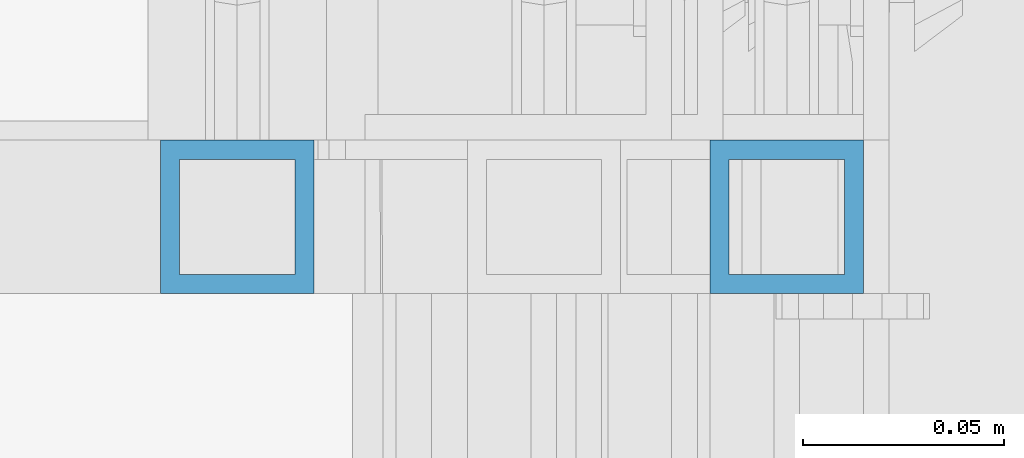
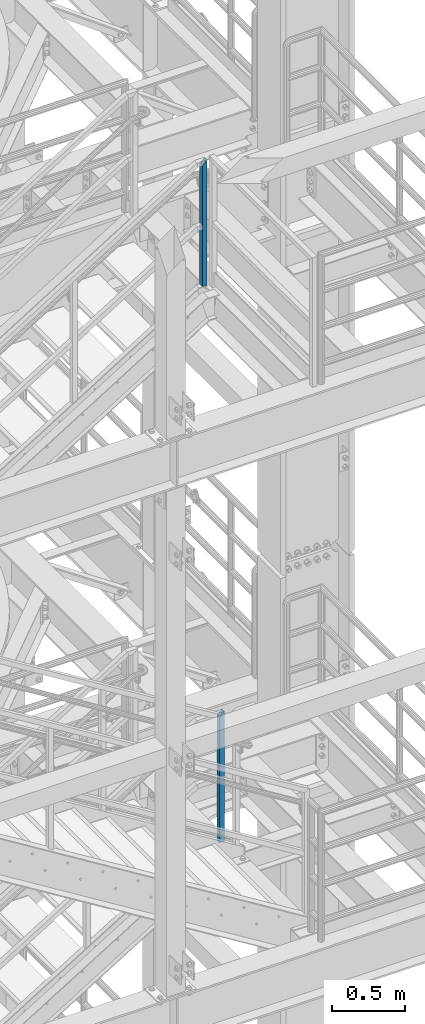
# One storey, part 643 of 1876: 2 columns, 2 elements without a shape of their own.
"""IFC2X3 building model written with IfcOpenShell, lengths in millimetres."""

from ifc_helpers import new_model, si_unit, frame, origin_with_axes, place, context, subcontext, project, spatial, faceted_brep, material, type_object, element, aggregate, save


model = new_model("IFC2X3")

# Units and contexts
model_context = context("Model", 3, precision=1e-05, world=origin_with_axes())
body_context = subcontext(model_context, "Body", "Model", "MODEL_VIEW")
ifc_project = project(units=[si_unit("LENGTHUNIT", "METRE", prefix="MILLI"), si_unit("AREAUNIT", "SQUARE_METRE"), si_unit("VOLUMEUNIT", "CUBIC_METRE"), si_unit("MASSUNIT", "GRAM", prefix="KILO"), si_unit("TIMEUNIT", "SECOND"), si_unit("PLANEANGLEUNIT", "RADIAN"), si_unit("SOLIDANGLEUNIT", "STERADIAN"), si_unit("THERMODYNAMICTEMPERATUREUNIT", "DEGREE_CELSIUS"), si_unit("LUMINOUSINTENSITYUNIT", "LUMEN")], contexts=[model_context])

# Site, building, storey
site_placement = place(None, origin_with_axes())
site = spatial("IfcSite", under=ifc_project, at=site_placement, CompositionType="ELEMENT")
building_placement = place(site_placement, origin_with_axes())
building = spatial("IfcBuilding", under=site, at=building_placement, Name="Undefined", CompositionType="ELEMENT")
storey_placement = place(building_placement, origin_with_axes())
storey = spatial("IfcBuildingStorey", under=building, at=storey_placement, Name="Undefined", CompositionType="ELEMENT", Elevation=0.0)

# Assembly, column
assembly_1_placement = place(storey_placement, origin_with_axes())
assembly_1 = element("IfcElementAssembly", 1, at=assembly_1_placement, inside=storey, Name="RAIL", AssemblyPlace="NOTDEFINED", PredefinedType="RIGID_FRAME")
ifc_material = material()
column_type = type_object("IfcColumnType", Name="HSS1-1/2X1-1/2X3/16", PredefinedType="NOTDEFINED")
column_1_placement = place(assembly_1_placement, frame((6273.80000001181, -5734.05000114554, 13309.6000000019), z_axis=(-1.0, 0.0, 0.0), x_axis=(0.0, 0.0, 1.0)))
column_1 = element("IfcColumn", 2, at=column_1_placement, type_object=column_type, material=ifc_material, Name="POST", ObjectType="HSS1-1/2X1-1/2X3/16", context=body_context, shape_type="Brep", body=[
    faceted_brep([(0.0, 14.2874994260001, -14.2874994260001), (0.0, -14.2874994260001, -14.2874994260001), (1081.08750016379, -14.2874994260001, -14.2874994260001), (1081.08750230446, 14.2874994260001, -14.2874994260001), (0.0, -14.2874994260001, 14.2874994260001), (1052.51250130933, -14.2874994260001, 14.2874994260001), (0.0, 14.2874994260001, 14.2874994260001), (1052.51250345492, 14.2874994260001, 14.2874994260001), (0.0, 19.0499992349996, -19.0499992350001), (0.0, 19.0499992349996, 19.0499992349996), (1047.7500040031, 19.0499992349996, 19.0499992349996), (1085.85000247064, 19.0499992349996, -19.0499992349996), (0.0, -19.0499992349996, 19.0499992349996), (1047.75000114315, -19.0499992349996, 19.0499992349996), (0.0, -19.0499992349996, -19.0499992350001), (1085.8499996156, -19.0499992349996, -19.0499992349996)], [[[0, 1, 2, 3]], [[1, 4, 5, 2]], [[4, 6, 7, 5]], [[6, 0, 3, 7]], [[8, 9, 10, 11]], [[9, 12, 13, 10]], [[12, 14, 15, 13]], [[14, 8, 11, 15]], [[13, 15, 11, 10], [5, 7, 3, 2]], [[14, 12, 9, 8], [6, 4, 1, 0]]]),
])
aggregate(assembly_1, [column_1])

assembly_2_placement = place(storey_placement, origin_with_axes())
assembly_2 = element("IfcElementAssembly", 3, at=assembly_2_placement, inside=storey, Name="RAIL", AssemblyPlace="NOTDEFINED", PredefinedType="RIGID_FRAME")
column_2_placement = place(assembly_2_placement, frame((6137.27499963888, -5734.05000114554, 18008.6000004074), z_axis=(-1.0, 0.0, 0.0), x_axis=(0.0, 0.0, 1.0)))
column_2 = element("IfcColumn", 4, at=column_2_placement, type_object=column_type, material=ifc_material, Name="POST", ObjectType="HSS1-1/2X1-1/2X3/16", context=body_context, shape_type="Brep", body=[
    faceted_brep([(1022.350000765, -19.0499992349996, 19.0499992349996), (1022.350000765, 19.0499992349996, 19.0499992349996), (9.58492796205246, 19.0499992349996, 19.0499992349996), (9.58492796205246, -19.0499992349996, 19.0499992349996), (1060.449999235, -19.0499992349996, -19.0499992349996), (9.58492796205246, -19.0499992349996, -19.0499992349996), (1060.449999235, 19.0499992349996, -19.0499992349996), (9.58492796205246, 19.0499992349996, -19.0499992349996), (1027.112500574, -14.2874994260001, 14.2874994260001), (1027.112500574, 14.2874994260001, 14.2874994260001), (1055.687499426, 14.2874994260001, -14.2874994260001), (1055.687499426, -14.2874994260001, -14.2874994260001), (9.58492796205246, -14.2874994260001, 14.2874994260001), (9.58492796205246, 14.2874994260001, 14.2874994260001), (9.58492796205246, 14.2874994260001, -14.2874994260001), (9.58492796205246, -14.2874994260001, -14.2874994260001)], [[[0, 1, 2, 3]], [[4, 0, 3, 5]], [[6, 4, 5, 7]], [[1, 6, 7, 2]], [[0, 4, 6, 1], [8, 9, 10, 11]], [[9, 8, 12, 13]], [[10, 9, 13, 14]], [[11, 10, 14, 15]], [[8, 11, 15, 12]], [[7, 5, 3, 2], [14, 13, 12, 15]]]),
])
aggregate(assembly_2, [column_2])

save(model, "model.ifc")
